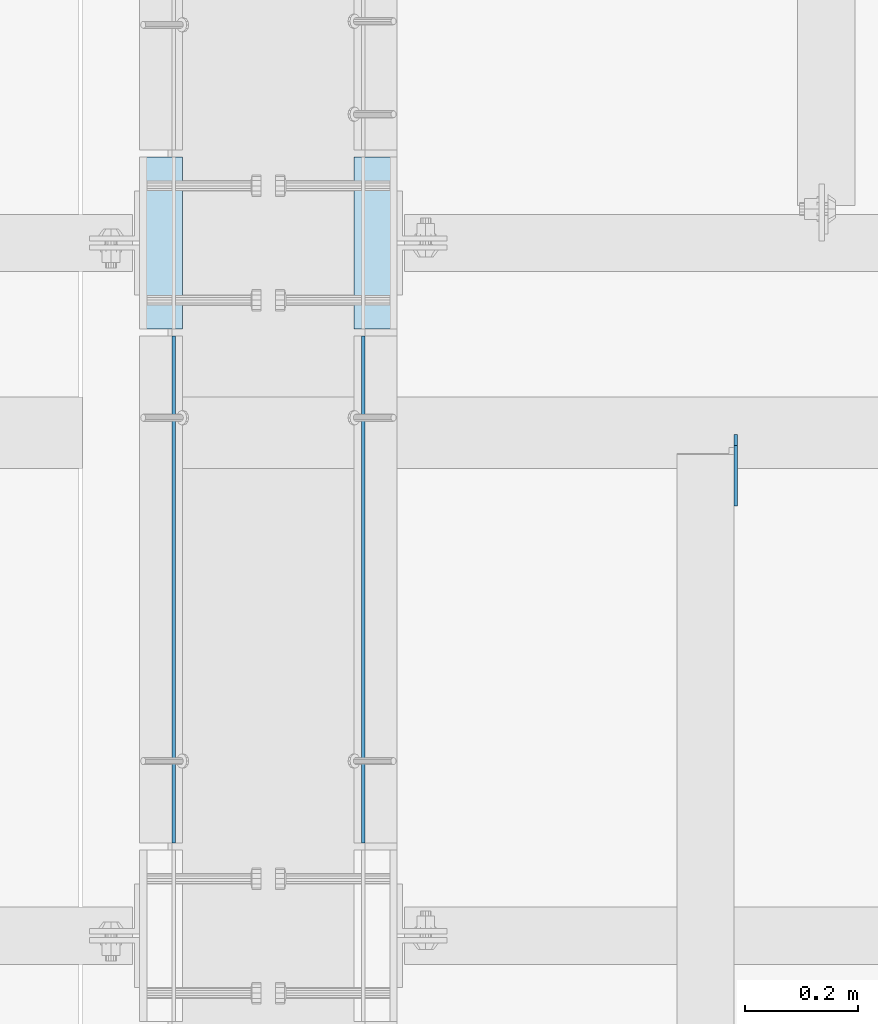
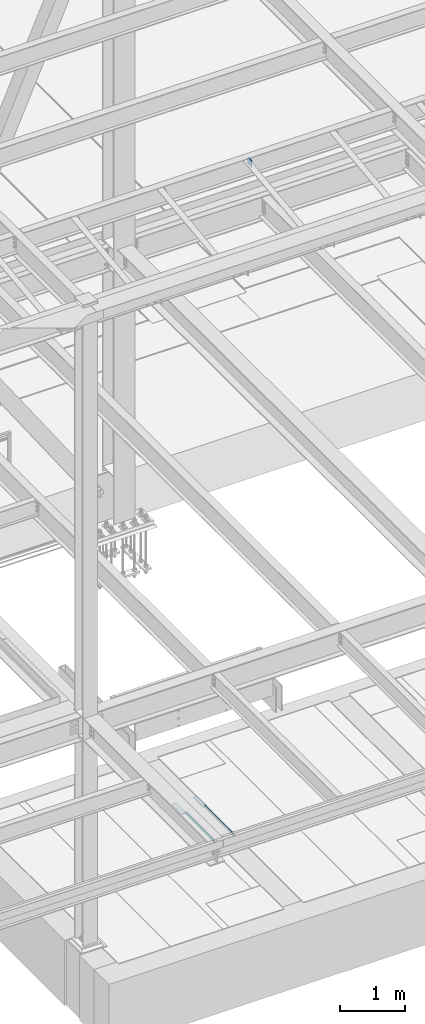
# One storey, part 3118 of 3843: 5 plates, 5 elements without a shape of their own.
"""IFC2X3 building model written with IfcOpenShell, lengths in millimetres."""

from ifc_helpers import new_model, si_unit, frame, origin_with_axes, place, context, subcontext, project, spatial, faceted_brep, material, type_object, element, aggregate, save


model = new_model("IFC2X3")

# Units and contexts
model_context = context("Model", 3, precision=1e-05, world=origin_with_axes())
body_context = subcontext(model_context, "Body", "Model", "MODEL_VIEW")
ifc_project = project(units=[si_unit("LENGTHUNIT", "METRE", prefix="MILLI"), si_unit("AREAUNIT", "SQUARE_METRE"), si_unit("VOLUMEUNIT", "CUBIC_METRE"), si_unit("MASSUNIT", "GRAM", prefix="KILO"), si_unit("TIMEUNIT", "SECOND"), si_unit("PLANEANGLEUNIT", "RADIAN"), si_unit("SOLIDANGLEUNIT", "STERADIAN"), si_unit("THERMODYNAMICTEMPERATUREUNIT", "DEGREE_CELSIUS"), si_unit("LUMINOUSINTENSITYUNIT", "LUMEN")], contexts=[model_context])

# Site, building, storey
site_placement = place(None, origin_with_axes())
site = spatial("IfcSite", under=ifc_project, at=site_placement, CompositionType="ELEMENT")
building_placement = place(site_placement, origin_with_axes())
building = spatial("IfcBuilding", under=site, at=building_placement, Name="Undefined", CompositionType="ELEMENT")
storey_placement = place(building_placement, origin_with_axes())
storey = spatial("IfcBuildingStorey", under=building, at=storey_placement, Name="Undefined", CompositionType="ELEMENT", Elevation=0.0)

# Assembly, plate
assembly_1_placement = place(storey_placement, origin_with_axes())
assembly_1 = element("IfcElementAssembly", 1, at=assembly_1_placement, inside=storey, Name="EMBED PLATE", AssemblyPlace="NOTDEFINED", PredefinedType="RIGID_FRAME")
ifc_material_1 = material(Name="STEEL/A36")
plate_type_1 = type_object("IfcPlateType", PredefinedType="NOTDEFINED")
plate_1_placement = place(assembly_1_placement, frame((58953.3999969482, 17306.925, 30426.025), z_axis=(0.0, 1.0, 0.0), x_axis=(1.0, 0.0, 0.0)))
plate_1 = element("IfcPlate", 2, at=plate_1_placement, type_object=plate_type_1, material=ifc_material_1, Name="PLATE", context=body_context, shape_type="Brep", body=[
    faceted_brep([(0.0, -3.17499999999927, 0.0), (0.0, -3.17499999999927, 304.800000000003), (0.0, 3.17499999999927, 304.800000000003), (0.0, 3.17499999999927, 0.0), (76.1999999999971, -3.17499999999927, 304.799999999996), (76.1999999999971, 3.17499999999927, 304.799999999996), (76.1999999999971, -3.17499999999927, 0.0), (76.1999999999971, 3.17499999999927, 0.0)], [[[0, 1, 2, 3]], [[1, 4, 5, 2]], [[4, 6, 7, 5]], [[6, 0, 3, 7]], [[5, 7, 3, 2]], [[6, 4, 1, 0]]]),
])
aggregate(assembly_1, [plate_1])

assembly_2_placement = place(storey_placement, origin_with_axes())
assembly_2 = element("IfcElementAssembly", 3, at=assembly_2_placement, inside=storey, Name="EMBED PLATE", AssemblyPlace="NOTDEFINED", PredefinedType="RIGID_FRAME")
plate_2_placement = place(assembly_2_placement, frame((59410.6000030518, 17611.725, 30426.025), z_axis=(0.0, -1.0, 0.0), x_axis=(-1.0, 0.0, 0.0)))
plate_2 = element("IfcPlate", 4, at=plate_2_placement, type_object=plate_type_1, material=ifc_material_1, Name="PLATE", context=body_context, shape_type="Brep", body=[
    faceted_brep([(0.0, -3.17499999999927, 0.0), (0.0, -3.17499999999927, 304.800000000003), (0.0, 3.17499999999927, 304.800000000003), (0.0, 3.17499999999927, 0.0), (76.1999999999971, -3.17499999999927, 304.799999999996), (76.1999999999971, 3.17499999999927, 304.799999999996), (76.1999999999971, -3.17499999999927, 0.0), (76.1999999999971, 3.17499999999927, 0.0)], [[[0, 1, 2, 3]], [[1, 4, 5, 2]], [[4, 6, 7, 5]], [[6, 0, 3, 7]], [[5, 7, 3, 2]], [[6, 4, 1, 0]]]),
])
aggregate(assembly_2, [plate_2])

assembly_3_placement = place(storey_placement, origin_with_axes())
assembly_3 = element("IfcElementAssembly", 5, at=assembly_3_placement, inside=storey, Name="ANGLE", AssemblyPlace="NOTDEFINED", PredefinedType="RIGID_FRAME")
plate_type_2 = type_object("IfcPlateType", PredefinedType="NOTDEFINED")
plate_3_placement = place(assembly_3_placement, frame((59350.2749999714, 16394.1123981715, 30429.2000030518), z_axis=(0.0, 0.999999999997942, -2.02899998962774e-06), x_axis=(0.0, 2.02899999567308e-06, 0.999999999997942)))
plate_3 = element("IfcPlate", 6, at=plate_3_placement, type_object=plate_type_2, material=ifc_material_1, Name="PLATE", context=body_context, shape_type="Brep", body=[
    faceted_brep([(0.0, -3.17499999999927, 0.0), (0.00181156927283155, -3.1749999984022, 900.111999510274), (0.00181156927283155, 3.17500000159635, 900.11199951026), (0.0, 3.17499999999927, 0.0), (50.8018112192949, -3.1749999984022, 900.111999510213), (50.8018112192949, 3.17500000159635, 900.111999510198), (50.7999954217848, -3.17499999999563, -7.27595761418343e-12), (50.7999954217848, 3.17500000001019, -1.09139364212751e-11)], [[[0, 1, 2, 3]], [[1, 4, 5, 2]], [[4, 6, 7, 5]], [[6, 0, 3, 7]], [[5, 7, 3, 2]], [[6, 4, 1, 0]]]),
])
aggregate(assembly_3, [plate_3])

assembly_4_placement = place(storey_placement, origin_with_axes())
assembly_4 = element("IfcElementAssembly", 7, at=assembly_4_placement, inside=storey, Name="ANGLE", AssemblyPlace="NOTDEFINED", PredefinedType="RIGID_FRAME")
plate_4_placement = place(assembly_4_placement, frame((59013.7250014031, 16394.1125001839, 30429.2000030518), z_axis=(0.0, 0.999999999997942, -2.02899998962774e-06), x_axis=(0.0, 2.02899999567308e-06, 0.999999999997942)))
plate_4 = element("IfcPlate", 8, at=plate_4_placement, type_object=plate_type_2, material=ifc_material_1, Name="PLATE", context=body_context, shape_type="Brep", body=[
    faceted_brep([(0.0, -3.17499999999927, 0.0), (0.00181156927283155, -3.1749999984022, 900.111999510274), (0.00181156927283155, 3.17500000159635, 900.11199951026), (0.0, 3.17499999999927, 0.0), (50.8018112192949, -3.1749999984022, 900.111999510213), (50.8018112192949, 3.17500000159635, 900.111999510198), (50.7999954217848, -3.17499999999563, -7.27595761418343e-12), (50.7999954217848, 3.17500000001019, -1.09139364212751e-11)], [[[0, 1, 2, 3]], [[1, 4, 5, 2]], [[4, 6, 7, 5]], [[6, 0, 3, 7]], [[5, 7, 3, 2]], [[6, 4, 1, 0]]]),
])
aggregate(assembly_4, [plate_4])

assembly_5_placement = place(storey_placement, origin_with_axes())
assembly_5 = element("IfcElementAssembly", 9, at=assembly_5_placement, inside=storey, Name="BEAM", AssemblyPlace="NOTDEFINED", PredefinedType="RIGID_FRAME")
ifc_material_2 = material(Name="STEEL/A572-50")
plate_type_3 = type_object("IfcPlateType", PredefinedType="NOTDEFINED")
plate_5_placement = place(assembly_5_placement, frame((60012.2625, 17118.965, 42330.6875), z_axis=(0.0, 0.0, 1.0), x_axis=(0.0, -1.0, 0.0)))
plate_5 = element("IfcPlate", 10, at=plate_5_placement, type_object=plate_type_3, material=ifc_material_2, Name="PLATE", context=body_context, shape_type="Brep", body=[
    faceted_brep([(0.0, -3.17499999999927, 0.0), (0.0, -3.17500000000291, 107.950000000004), (0.0, 3.17500000000291, 107.950000000004), (0.0, 3.17499999999927, 0.0), (19.0500000000029, -3.17500000000291, 127.0), (19.0500000000029, 3.17500000000291, 127.0), (127.0, -3.17500000000291, 127.0), (127.0, 3.17500000000291, 127.0), (127.0, -3.17500000000291, 0.0), (127.0, 3.17500000000291, 0.0)], [[[0, 1, 2, 3]], [[1, 4, 5, 2]], [[4, 6, 7, 5]], [[6, 8, 9, 7]], [[8, 0, 3, 9]], [[5, 7, 9, 3, 2]], [[8, 6, 4, 1, 0]]]),
])
aggregate(assembly_5, [plate_5])

save(model, "model.ifc")
